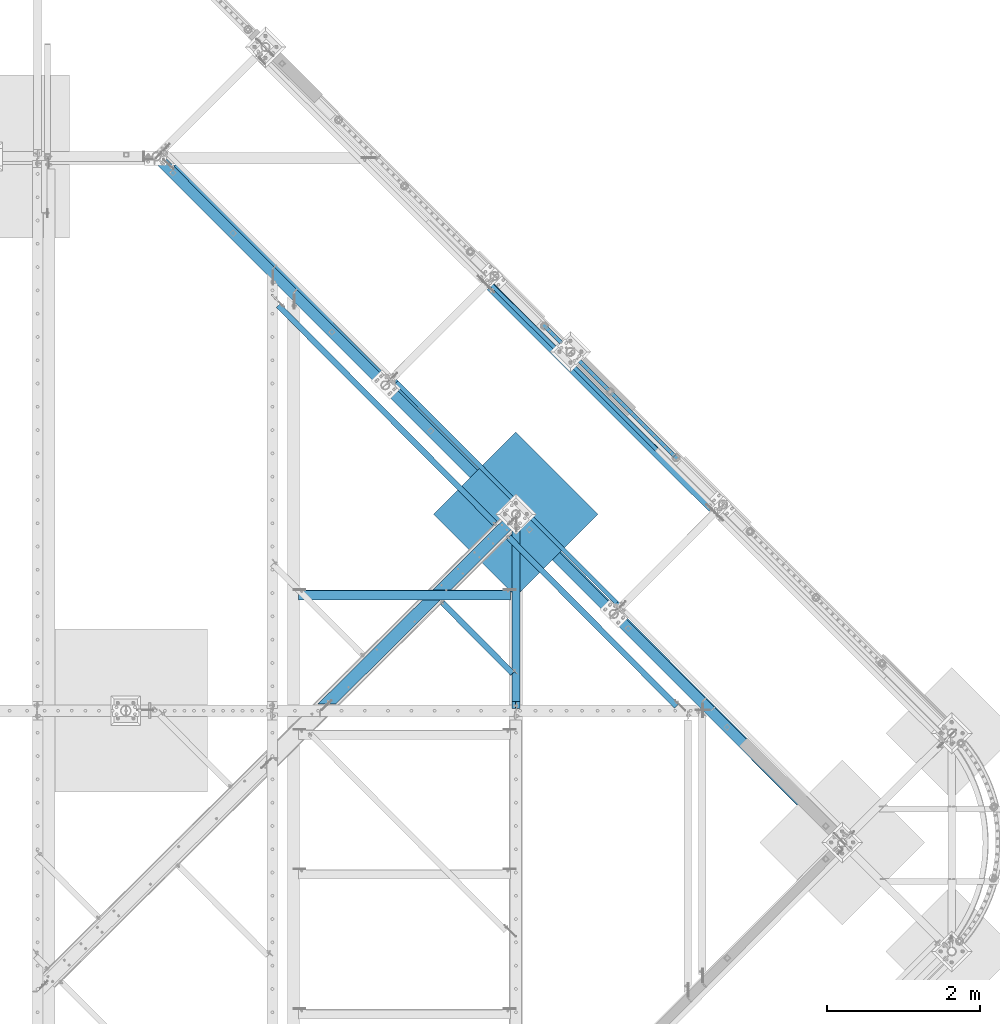
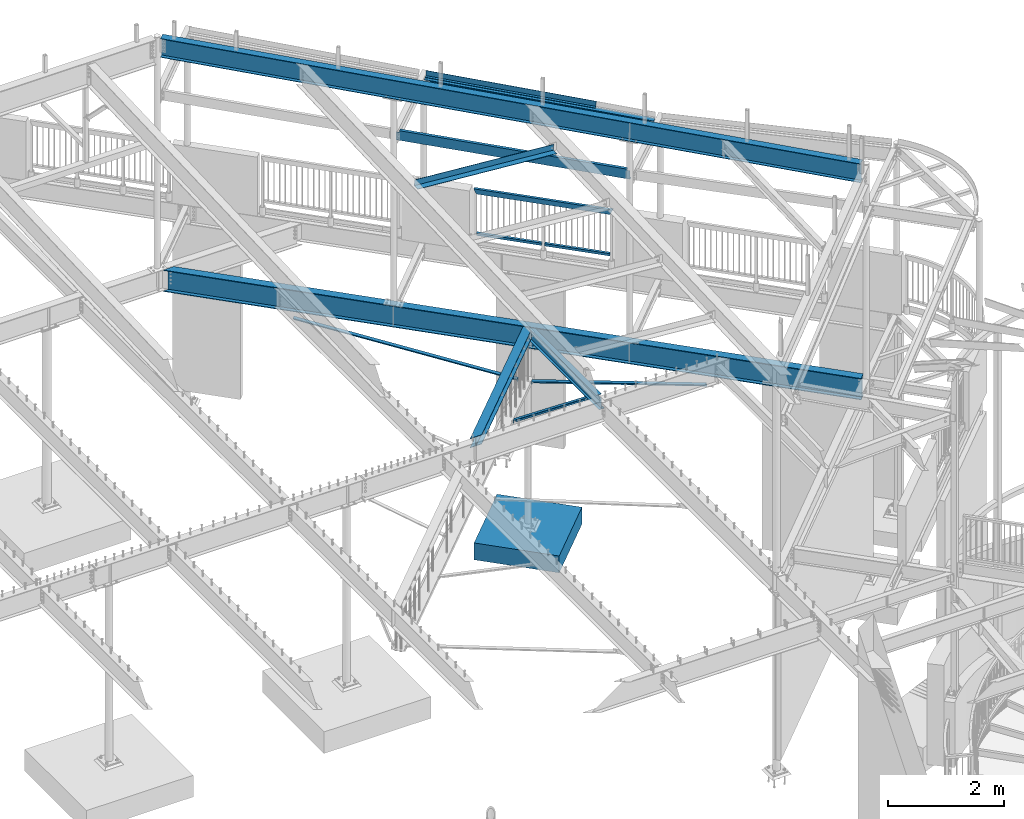
# One storey, part 373 of 975: 15 beams.
"""IFC2X3 building model written with IfcOpenShell, lengths in millimetres."""

from ifc_helpers import new_model, si_unit, frame, origin_with_axes, place, context, subcontext, project, spatial, faceted_brep, material, type_object, element, save


model = new_model("IFC2X3")

# Units and contexts
model_context = context("Model", 3, precision=1e-05, world=origin_with_axes())
body_context = subcontext(model_context, "Body", "Model", "MODEL_VIEW")
ifc_project = project(units=[si_unit("LENGTHUNIT", "METRE", prefix="MILLI"), si_unit("AREAUNIT", "SQUARE_METRE"), si_unit("VOLUMEUNIT", "CUBIC_METRE"), si_unit("MASSUNIT", "GRAM", prefix="KILO"), si_unit("TIMEUNIT", "SECOND"), si_unit("PLANEANGLEUNIT", "RADIAN"), si_unit("SOLIDANGLEUNIT", "STERADIAN"), si_unit("THERMODYNAMICTEMPERATUREUNIT", "DEGREE_CELSIUS"), si_unit("LUMINOUSINTENSITYUNIT", "LUMEN")], contexts=[model_context])

# Site, building, storey
site_placement = place(None, origin_with_axes())
site = spatial("IfcSite", under=ifc_project, at=site_placement, CompositionType="ELEMENT")
building_placement = place(site_placement, origin_with_axes())
building = spatial("IfcBuilding", under=site, at=building_placement, Name="Undefined", CompositionType="ELEMENT")
storey_placement = place(building_placement, origin_with_axes())
storey = spatial("IfcBuildingStorey", under=building, at=storey_placement, Name="Undefined", CompositionType="ELEMENT", Elevation=0.0)

# Beams
ifc_material_1 = material(Name="STEEL/A36")
beam_type_1 = type_object("IfcBeamType", Name="L3X3X3/16", PredefinedType="NOTDEFINED")
beam_1_placement = place(storey_placement, frame((28897.6420101106, 14778.4779433271, 2870.2), z_axis=(-0.709199630836852, -0.705007718837796, 0.0), x_axis=(0.0, 0.0, 1.0)))
element("IfcBeam", 1, at=beam_1_placement, inside=storey, type_object=beam_type_1, material=ifc_material_1, Name="ANGLE", ObjectType="L3X3X3/16", context=body_context, shape_type="Brep", body=[
    faceted_brep([(25.3999993263515, 33.3375000169253, 38.0997831568893), (25.4000002045141, 38.1000000169333, 38.099783156882), (25.4000002078405, 38.100000016997, -38.1002168458144), (25.3999993296779, 33.3375003807087, -38.0996631641319), (25.3999993294701, 33.337500016989, -33.3377168456427), (89.2477246585408, 33.3375000829601, -33.3382619254771), (89.2477246587487, 33.3374998887612, -38.1012691648793), (26.5509402113553, -0.90219007239466, -38.100226671635), (26.5510748253832, -0.90211636328786, -33.3377266726166), (109.802765615811, -4.29845954950542, -33.3399316989671), (47.1055311905088, -38.5383953173441, -33.3393964411225), (736.520643746514, -1300.93623608511, -33.438308348439), (799.217878199897, -1266.69630036868, -33.4388436062909), (46.8646592112509, -38.0999999688338, -33.3379000934765), (46.8644103387105, -38.099999968832, -38.10040009152), (47.1053429026992, -38.5381249909187, -38.1018964297218), (736.520612510684, -1300.93625333881, -38.200808359572), (113.982392956355, -2.01552683855698, -38.102467371431), (803.397662594292, -1264.41365524128, -38.2013793012811), (92.0730134809646, 38.1000000613858, -38.1007860456557), (92.0769954416164, 38.1000000613221, 38.0992139230439), (113.985405561312, -2.01985206136487, 38.097532446187), (803.398162367575, -1264.4133791822, 37.9986208768532), (109.805589932958, -4.30251444588794, 38.0975681300406), (799.21834673735, -1266.69604156329, 37.9986565607105), (89.2514577452253, 33.3375000594315, 38.0992380451789)], [[[0, 1, 2, 3, 4]], [[5, 6, 7, 8]], [[4, 3, 6, 5]], [[9, 10, 11, 12]], [[10, 13, 14, 15, 16, 11]], [[15, 17, 18, 16]], [[19, 20, 21, 17]], [[17, 21, 22, 18]], [[21, 23, 24, 22]], [[12, 11, 16, 18, 22, 24]], [[23, 9, 12, 24]], [[25, 5, 9, 23]], [[13, 10, 9, 5, 8]], [[14, 13, 8, 7]], [[2, 19, 17, 15, 14, 7, 6, 3]], [[20, 19, 2, 1]], [[25, 23, 21, 20, 1, 0]], [[5, 25, 0, 4]]]),
])
beam_2_placement = place(storey_placement, frame((26613.91134576, 18805.1515826589, 3499.2069360264), z_axis=(-0.709199630836852, -0.705007718837796, 0.0), x_axis=(0.698402953621949, -0.702555536619701, -0.136561459926078)))
element("IfcBeam", 2, at=beam_2_placement, inside=storey, type_object=beam_type_1, material=ifc_material_1, Name="ANGLE", ObjectType="L3X3X3/16", context=body_context, shape_type="Brep", body=[
    faceted_brep([(4204.02731316171, -38.1000131169067, -33.3374999955777), (4204.02731316172, -38.1000130379352, -38.0999999956366), (4204.02731334885, 33.3374881753789, -38.0999999960804), (4204.02731333657, 33.3374881686541, -33.3374999966072), (4212.56568141171, -28.6007595276697, -38.0999999961605), (4212.56568170814, -28.6007594877619, -33.3374999955522), (4217.28356452321, -27.9503860965106, 38.1000000045351), (4212.56568170962, -28.6007595019037, 38.1000000045096), (4217.28356477547, -27.9503860464329, -38.0999999955275), (150.946186465858, -38.1000004248108, -33.3374999999724), (150.946186465987, -38.1000004248108, -38.0999999999767), (4141.76209717846, -38.1000116561163, -38.0999999967644), (4141.76209717834, -38.1000116561154, -33.3374999967637), (150.946186665603, 38.0999995751899, -38.0999999998567), (150.946186653002, 33.337499575191, -33.3374999998632), (150.946186651126, 33.3374995752001, 38.1000000001986), (150.9461866636, 38.0999995751999, 38.1000000002059), (4208.1783277454, 38.0999881569805, 38.1000000034655), (4208.17832774723, 38.0999881569714, -38.099999996597), (4204.02731333484, 33.3374881686623, 38.1000000034583)], [[[0, 1, 2, 3]], [[3, 2, 4, 5]], [[6, 7, 5, 4, 8]], [[9, 10, 11, 12]], [[13, 10, 9, 14, 15, 16]], [[13, 16, 17, 18]], [[18, 17, 6, 8]], [[2, 1, 11, 10, 13, 18, 8, 4]], [[12, 11, 1, 0]], [[14, 9, 12, 0, 3]], [[15, 14, 3, 19]], [[19, 3, 5, 7]], [[17, 16, 15, 19, 7, 6]]]),
])
beam_3_placement = place(storey_placement, frame((29762.5164907667, 15637.825378845, 2870.19999999883), z_axis=(-0.709199630836852, -0.705007718837796, 0.0), x_axis=(0.0, 0.0, 1.0)))
element("IfcBeam", 3, at=beam_3_placement, inside=storey, type_object=beam_type_1, material=ifc_material_1, Name="ANGLE", ObjectType="L3X3X3/16", context=body_context, shape_type="Brep", body=[
    faceted_brep([(25.3999988471701, 33.3375000072774, 38.1002199808863), (25.3999981669754, 38.1000000072836, 38.1002199808863), (25.3999981825341, 38.1000000073491, -38.0997800218902), (25.3999988627288, 33.337499142317, -38.1001112534723), (25.3999988617566, 33.3375000073374, -33.3372800217148), (88.0214063803228, 33.3375000188971, -33.3367376821552), (88.0214063812955, 33.3374998225809, -38.0990429855083), (17.4978253848435, 21.9431252632712, -38.0998484595366), (17.4977459579104, 21.9431126255986, -33.3373484600525), (97.801356415584, -27.1994682261393, -33.3356167277307), (27.2784030916505, -38.5937413643314, -33.3362274994943), (520.8336936932, -3093.37190596623, -33.2346009552493), (591.356647031154, -3081.97763291482, -33.2339901834857), (27.1995347129787, -38.0999999922569, -33.3372644366973), (27.1997051803933, -38.0999999922551, -38.0997644353993), (27.2784682359961, -38.5938892782033, -38.098727496741), (520.833733920797, -3093.37189966205, -37.9971009576329), (102.502951781525, -26.4399979308018, -38.0980760068705), (596.058217481281, -3081.21800840721, -37.9964494677515), (92.0763682910315, 38.1000000264012, -38.099202563877), (92.0736408123948, 38.1000000263375, 38.1007974152781), (102.501909471998, -26.4376313087778, 38.1019239491761), (596.057573839732, -3081.21810927416, 38.2035505703825), (97.8003792504023, -27.1972495179907, 38.1018832310583), (591.356043617202, -3081.97772747758, 38.203509852261), (88.0188493679802, 33.3375000251708, 38.1007622983088)], [[[0, 1, 2, 3, 4]], [[5, 6, 7, 8]], [[4, 3, 6, 5]], [[9, 10, 11, 12]], [[10, 13, 14, 15, 16, 11]], [[15, 17, 18, 16]], [[19, 20, 21, 17]], [[17, 21, 22, 18]], [[21, 23, 24, 22]], [[12, 11, 16, 18, 22, 24]], [[23, 25, 5, 9, 12, 24]], [[13, 10, 9, 5, 8]], [[14, 13, 8, 7]], [[2, 19, 17, 15, 14, 7, 6, 3]], [[20, 19, 2, 1]], [[25, 23, 21, 20, 1, 0]], [[5, 25, 0, 4]]]),
])
ifc_material_2 = material()
beam_type_2 = type_object("IfcBeamType", Name="HSS2X2X.188_TUBES", PredefinedType="NOTDEFINED")
beam_4_placement = place(storey_placement, frame((31066.8280807556, 17567.7896415463, 4229.10075294121), z_axis=(-0.707143406238003, -0.707070154237976, 0.0), x_axis=(-0.707070154237841, 0.707143406237869, -6.17000000467233e-07)))
element("IfcBeam", 4, at=beam_4_placement, inside=storey, type_object=beam_type_2, material=ifc_material_2, Name="HANDRAIL", ObjectType="HSS2X2X.188_TUBES", context=body_context, shape_type="Brep", body=[
    faceted_brep([(25.4008090784755, 20.6375000000126, -20.6375000000844), (25.4008182261714, -20.6374999999962, -20.6375000000407), (1193.80731114153, -20.6374999996497, -20.6375000016997), (1193.80733660824, 20.6375000003582, -20.6375000017506), (25.3986803055723, -20.6374999999962, 20.6375000000189), (1193.80517322093, -20.6374999996497, 20.63749999836), (25.3986711578782, 20.6375000000116, 20.6374999999753), (1193.80519868763, 20.6375000003572, 20.6374999983091), (25.4010547061143, 25.4000000000133, -25.400000000096), (25.3984234192258, 25.4000000000124, 25.3999999999724), (1193.80495494295, 25.400000000358, 25.3999999983134), (1193.80758622984, 25.400000000358, -25.4000000017622), (25.3984346779298, -25.3999999999969, 25.4000000000306), (1193.80492359932, -25.3999999996513, 25.3999999983716), (25.4010659648184, -25.3999999999969, -25.4000000000451), (1193.80755488621, -25.3999999996513, -25.400000001704)], [[[0, 1, 2, 3]], [[1, 4, 5, 2]], [[4, 6, 7, 5]], [[6, 0, 3, 7]], [[8, 9, 10, 11]], [[9, 12, 13, 10]], [[12, 14, 15, 13]], [[14, 8, 11, 15]], [[13, 15, 11, 10], [5, 7, 3, 2]], [[14, 12, 9, 8], [6, 4, 1, 0]]]),
])
beam_5_placement = place(storey_placement, frame((31928.891109491, 16705.637303814, 4229.10009527429), z_axis=(-0.707143406238003, -0.707070154237976, 0.0), x_axis=(-0.707070154237873, 0.7071434062379, 5.39000000270782e-07)))
element("IfcBeam", 5, at=beam_5_placement, inside=storey, type_object=beam_type_2, material=ifc_material_2, Name="HANDRAIL", ObjectType="HSS2X2X.188_TUBES", context=body_context, shape_type="Brep", body=[
    faceted_brep([(25.3959352503016, 20.6374999999971, -20.6375000000698), (25.395957497507, -20.637500000008, -20.6375000000553), (1193.80522150229, -20.6375000002545, -20.6375000017215), (1193.80516464068, 20.6374999997506, -20.637500001736), (25.3984002056568, -20.637500000008, 20.6374999999971), (1193.80308358158, -20.6375000002545, 20.6374999983382), (25.3983779584496, 20.637499999998, 20.6374999999898), (1193.80302671998, 20.6374999997506, 20.6374999983236), (25.3956508323763, 25.3999999999978, -25.4000000000815), (25.3986572424046, 25.3999999999978, 25.3999999999942), (1193.80277347587, 25.3999999997513, 25.399999998328), (1193.80540476288, 25.3999999997513, -25.4000000017404), (25.398684623583, -25.4000000000096, 25.4000000000087), (1193.80284345937, -25.4000000002561, 25.3999999983498), (25.3956782135529, -25.4000000000096, -25.4000000000597), (1193.8054747464, -25.400000000257, -25.4000000017259)], [[[0, 1, 2, 3]], [[1, 4, 5, 2]], [[4, 6, 7, 5]], [[6, 0, 3, 7]], [[8, 9, 10, 11]], [[9, 12, 13, 10]], [[12, 14, 15, 13]], [[14, 8, 11, 15]], [[13, 15, 11, 10], [5, 7, 3, 2]], [[14, 12, 9, 8], [6, 4, 1, 0]]]),
])
beam_type_3 = type_object("IfcBeamType", Name="HSS2X4X.188_TUBES", PredefinedType="NOTDEFINED")
beam_6_placement = place(storey_placement, frame((31928.8963945046, 16705.6425679698, 5130.80000000666), z_axis=(0.0, 0.0, 1.0), x_axis=(-0.70707231784675, 0.707141242846735, 0.0)))
element("IfcBeam", 6, at=beam_6_placement, inside=storey, type_object=beam_type_3, material=ifc_material_2, Name="GUARDRAIL", ObjectType="HSS2X4X.188_TUBES", context=body_context, shape_type="Brep", body=[
    faceted_brep([(23.0198915490837, 20.6374999999994, -46.0375000000031), (23.0198915283145, -20.6374999999966, -46.0375000000085), (2415.39077695601, -20.6374999954423, -46.0375000000004), (2415.39077695595, 20.63750000453, -46.0375000000004), (-23.0198845522937, -20.6374999999985, 46.0375000000058), (2461.43052065577, -20.637499995355, 46.0375000000004), (-23.0198845315244, 20.6374999999973, 46.0375000000113), (2461.43052065571, 20.6375000046173, 46.0375000000004), (25.4012592797953, 25.399999999999, -50.8000000000029), (-25.4012522574303, 25.3999999999967, 50.800000000012), (2463.81188670914, 25.4000000046217, 50.8000000000002), (2413.00941090251, 25.4000000045271, -50.8000000000002), (-25.401252282998, -25.3999999999983, 50.8000000000056), (2463.81188670921, -25.3999999953448, 50.8000000000002), (25.401259254224, -25.399999999996, -50.8000000000102), (2413.00941090258, -25.3999999954467, -50.8000000000002)], [[[0, 1, 2, 3]], [[1, 4, 5, 2]], [[4, 6, 7, 5]], [[6, 0, 3, 7]], [[8, 9, 10, 11]], [[9, 12, 13, 10]], [[12, 14, 15, 13]], [[14, 8, 11, 15]], [[13, 15, 11, 10], [5, 7, 3, 2]], [[14, 12, 9, 8], [6, 4, 1, 0]]]),
])
beam_type_4 = type_object("IfcBeamType", Name="C8X11.5", PredefinedType="NOTDEFINED")
beam_7_placement = place(storey_placement, frame((28212.0481476943, 17744.9910474199, 7442.2164682342), z_axis=(-0.0127286164433972, 0.0127331754435545, -0.999837911146882), x_axis=(0.706865566726338, -0.70711874472624, -0.0180042059930297)))
element("IfcBeam", 7, at=beam_7_placement, inside=storey, type_object=beam_type_4, material=ifc_material_1, Name="BEAM", ObjectType="C8X11.5", context=body_context, shape_type="Brep", body=[
    faceted_brep([(4160.56939785738, -28.5750000072912, -96.8355950008245), (4160.56939785738, -28.5750000072803, -101.600000000823), (4160.56939785748, 28.5749999926411, -101.600000000825), (4160.56939785724, 28.5749999926229, -88.8999998159643), (4160.56939785725, 19.0576241515737, -88.8999998159497), (4160.67436089326, 22.2249999926316, -88.3723150008282), (4161.53612777983, 28.5749999926156, -84.0399202979224), (4161.53612777984, 22.2249999926244, -84.0399202979124), (4164.28914168031, 28.5749999926084, -79.9197438297724), (4164.28914168033, 22.2249999926134, -79.9197438297633), (4168.40931814848, 28.5749999925902, -77.1667299292994), (4168.40931814849, 22.2249999925989, -77.1667299292894), (4173.26939766654, 28.5749999925829, -76.2000000067146), (4173.26939766655, 22.2249999925916, -76.2000000067046), (4208.15702952845, 22.2249999925261, -76.2000000066037), (4208.16773109051, 28.574999992521, -76.2000000066018), (18.4365642043003, -28.5750000001535, 101.599999999971), (18.3507709691185, -28.5750000001462, 96.8355949999732), (4211.18729057694, -28.5750000076659, 96.8355949991192), (4211.27308381212, -28.5750000076769, 101.599999999117), (18.5023770780217, 28.5749999997752, 101.599999999969), (4211.36939787061, 28.5749999922518, 101.599999999116), (76.340374749816, 22.2249999999513, -80.7383896419924), (76.3476872913989, 28.5749999999389, -80.7383896387919), (75.9720296713549, 28.5749999999716, -101.599999999994), (75.9062167974971, -28.5749999999534, -101.599999999992), (75.9920100326763, -28.5749999999571, -96.8355949999932), (76.2029097037275, 22.2249999999585, -88.372314999996), (75.4613027550622, 22.2249999999403, -75.8616926944906), (75.4686152966451, 28.5749999999316, -75.8616926912891), (72.7829137675853, 22.2249999999403, -71.6926182636198), (72.7902263091719, 28.5749999999316, -71.6926182604184), (68.7129682310797, 22.224999999944, -68.8658701387285), (68.7202807726608, 28.5749999999389, -68.8658701355262), (63.8710784593222, 22.2249999999549, -67.8117950972937), (63.8783910009015, 28.5749999999425, -67.8117950940923), (15.4601427503612, 22.2250000000386, -66.9400544949603), (15.4674552919441, 28.5750000000298, -66.9400544917626), (18.2568719625915, 22.2249999997985, 88.3723149999732), (4211.12050373465, 22.2249999922824, 88.3723149991192)], [[[0, 1, 2, 3, 4]], [[5, 4, 3, 6, 7]], [[7, 6, 8, 9]], [[9, 8, 10, 11]], [[11, 10, 12, 13]], [[14, 13, 12, 15]], [[16, 17, 18, 19]], [[20, 16, 19, 21]], [[22, 23, 24, 25, 26, 27]], [[28, 29, 23, 22]], [[30, 31, 29, 28]], [[32, 33, 31, 30]], [[34, 35, 33, 32]], [[36, 37, 35, 34]], [[38, 17, 16, 20, 37, 36]], [[17, 38, 39, 18]], [[21, 19, 18, 39, 14, 15]], [[10, 8, 6, 3, 2, 24, 23, 29, 31, 33, 35, 37, 20, 21, 15, 12]], [[25, 24, 2, 1]], [[26, 25, 1, 0]], [[27, 26, 0, 4, 5]], [[39, 38, 36, 34, 32, 30, 28, 22, 27, 5, 7, 9, 11, 13, 14]]]),
])
beam_type_5 = type_object("IfcBeamType", Name="L5X5X5/16", PredefinedType="NOTDEFINED")
beam_8_placement = place(storey_placement, frame((26920.8249998945, 14908.0718563048, 8526.04988149769), z_axis=(0.0796654699609281, 0.0, 0.996821655511107), x_axis=(0.996821655511107, 0.0, -0.0796654699609281)))
element("IfcBeam", 8, at=beam_8_placement, inside=storey, type_object=beam_type_5, material=ifc_material_1, ObjectType="L5X5X5/16", context=body_context, shape_type="Brep", body=[
    faceted_brep([(67.8053474811386, 63.5, -63.5000000000291), (67.805347481346, 63.5, 63.5000000000564), (2852.95282830662, 63.5, 63.5000000004839), (2852.9528283064, 63.5, -63.4999999996035), (67.805347481346, 55.5625, 63.5000000000564), (2852.95282830662, 55.5625, 63.5000000004839), (67.8053474811495, 55.5625, -55.5625000000236), (2852.95282830642, 55.5625, -55.562499999598), (67.8053474811495, -63.5, -55.5625000000236), (2852.95282830642, -63.5, -55.562499999598), (67.8053474811386, -63.5, -63.5000000000291), (2852.9528283064, -63.5, -63.4999999996035)], [[[0, 1, 2, 3]], [[1, 4, 5, 2]], [[4, 6, 7, 5]], [[6, 8, 9, 7]], [[8, 10, 11, 9]], [[10, 0, 3, 11]], [[5, 7, 9, 11, 3, 2]], [[10, 8, 6, 4, 1, 0]]]),
])
beam_type_6 = type_object("IfcBeamType", PredefinedType="NOTDEFINED")
beam_9_placement = place(storey_placement, frame((30576.5324890228, 17869.5424240011, 7405.78202579213), z_axis=(0.707509676766855, -0.705932996704191, -0.0329948699876541), x_axis=(0.706317571755026, 0.707895110754471, 0.0)))
element("IfcBeam", 9, at=beam_9_placement, inside=storey, type_object=beam_type_6, material=ifc_material_1, Name="DECK_EDGE", context=body_context, shape_type="Brep", body=[
    faceted_brep([(-1.44573277793825e-08, -3.17500000027667, -1523.99999999641), (7.79618858359754e-09, -3.17499999972461, 1523.99999999641), (1.44573277793825e-08, 3.17500000027576, 1523.99999999641), (-7.79255060479045e-09, 3.17499999972188, -1523.9999999964), (51.3282235099323, 3.17500000138443, 1523.99999999883), (51.3282235078514, 3.17500000009932, -1523.99999999884), (57.6782232685582, -3.17499999981101, -1523.99999999882), (57.6782232706391, -3.17499999852589, 1523.99999999885), (51.3282275774545, 111.125003231497, 1523.99999999851), (51.3282275765887, 111.125003228997, -1523.99999999916), (57.6782275774676, 111.125002992181, 1523.99999999851), (57.6782275766018, 111.125002989683, -1523.99999999917)], [[[0, 1, 2, 3]], [[3, 2, 4, 5]], [[1, 0, 6, 7]], [[5, 4, 8, 9]], [[4, 2, 1, 7, 10, 8]], [[7, 6, 11, 10]], [[6, 0, 3, 5, 9, 11]], [[10, 11, 9, 8]]]),
])
ifc_material_3 = material(Name="STEEL/A992")
beam_type_7 = type_object("IfcBeamType", Name="W8X24", PredefinedType="NOTDEFINED")
beam_10_placement = place(storey_placement, frame((27269.2700655018, 13392.1499999924, 3836.9875), z_axis=(0.0, 0.0, 1.0), x_axis=(0.709199573009271, 0.70500777700921, 0.0)))
element("IfcBeam", 10, at=beam_10_placement, inside=storey, type_object=beam_type_7, material=ifc_material_3, Name="BEAM", ObjectType="W8X24", context=body_context, shape_type="Brep", body=[
    faceted_brep([(3442.3759339616, -82.5499999972017, 100.0125), (3442.3759339616, -82.5499999972017, 90.4875000000002), (3521.28178049076, -3.17499999701249, 90.4875000000002), (3521.28178049076, -3.17499947762371, 100.0125), (3541.90348349708, -3.17500151060449, 100.0125), (3541.90348349708, -3.17499999699612, 90.4875000000002), (3442.3759339616, -82.5499999972017, -90.4875000000002), (3442.3759339616, -82.5499999972017, -100.0125), (3521.28178049076, -3.17499947762371, -100.0125), (3521.28178049076, -3.17499999701249, -90.4875000000002), (3541.90348349708, -3.17499999699612, -90.4875000000002), (3541.90348349708, -3.17500151060449, -100.0125), (125.462032533324, -3.17499999989559, -90.4875000000002), (205.308975989981, -82.549999999952, -90.4875000000002), (205.308975989981, -82.549999999952, -100.0125), (39.2273336001272, 82.5500000001612, -100.0125), (3541.90348349708, 82.550000003137, -100.0125), (39.2273336001272, 82.5500000001612, 90.4875000000002), (39.2273336001272, 82.5500000001612, 100.0125), (3541.90348349708, 82.550000003137, 100.0125), (3541.90348349708, 82.550000003137, 90.4875000000002), (119.074277056792, 3.17500000010477, 90.4875000000002), (3541.90348349708, 3.17500000301152, 90.4875000000002), (119.074277056792, 3.17500000010477, -90.4875000000002), (3541.90348349708, 3.17500000301152, -90.4875000000002), (39.2273336001272, 82.5500000001612, -90.4875000000002), (3541.90348349708, 82.550000003137, -90.4875000000002), (125.462032533324, -3.17499999989559, 90.4875000000002), (205.308975989981, -82.549999999952, 90.4875000000002), (205.308975989981, -82.549999999952, 100.0125)], [[[0, 1, 2, 3]], [[4, 3, 2, 5]], [[6, 7, 8, 9]], [[10, 9, 8, 11]], [[12, 13, 6, 9]], [[13, 14, 7, 6]], [[7, 14, 15, 16, 11, 8]], [[17, 18, 19, 20]], [[21, 17, 20, 22]], [[23, 21, 22, 24]], [[25, 23, 24, 26]], [[15, 25, 26, 16]], [[14, 13, 12, 27, 28, 29, 18, 17, 21, 23, 25, 15]], [[28, 27, 2, 1]], [[29, 28, 1, 0]], [[19, 18, 29, 0, 3, 4]], [[10, 11, 16, 26, 24, 22, 20, 19, 4, 5]], [[2, 27, 12, 9, 10, 5]]]),
])
beam_type_8 = type_object("IfcBeamType", Name="W10X12", PredefinedType="NOTDEFINED")
beam_11_placement = place(storey_placement, frame((29832.3, 13392.15, 3811.5875), z_axis=(0.0, 0.0, 1.0), x_axis=(0.0, 1.0, 0.0)))
element("IfcBeam", 11, at=beam_11_placement, inside=storey, type_object=beam_type_8, material=ifc_material_3, Name="BEAM", ObjectType="W10X12", context=body_context, shape_type="Brep", body=[
    faceted_brep([(2451.8772505076, 6.18835889114416, 125.4125), (2451.8772505076, 6.18835889114416, 120.65), (2451.8772505076, 50.7999999999993, 120.65), (2451.8772505076, 50.7999999999993, 125.4125), (2451.8772505076, 6.18835889114416, -120.65), (2451.8772505076, 6.18835889114416, -125.4125), (2451.8772505076, 50.7999999999993, -125.4125), (2451.8772505076, 50.7999999999993, -120.65), (118.268750000007, 50.8000000000002, 120.65), (118.268750000007, 50.8000000000002, 125.4125), (2448.04750552031, 2.38124999999854, 120.65), (118.268750000007, 2.38125000000036, 120.65), (29.3687500000015, 2.38125000000036, -120.65), (29.3687500000015, 50.8000000000002, -120.65), (29.3687500000015, 50.8000000000002, -125.4125), (29.3687500000015, -50.8000000000002, -125.4125), (29.3687500000015, -50.8000000000002, -120.65), (29.3687500000015, -2.38125000000036, -120.65), (29.3687500000015, -2.38125000000036, 100.0125), (29.3687500000015, 2.38125000000036, 100.0125), (105.568750190741, -2.38125000000036, 100.0125), (105.568750190741, 2.38125000000036, 100.0125), (110.428829708788, -2.38125000000036, 100.979229922588), (110.428829708788, 2.38125000000036, 100.979229922588), (114.549006176941, -2.38125000000036, 103.732243823066), (114.549006176941, 2.38125000000036, 103.732243823066), (117.302020077419, -2.38125000000036, 107.85242029122), (117.302020077419, 2.38125000000036, 107.85242029122), (118.268750000007, -2.38125000000036, 112.712499809265), (118.268750000007, 2.38125000000036, 112.712499809265), (2448.04750552031, 2.38124999999854, -120.65), (2394.55005340411, -50.7999999999993, -125.4125), (2394.55005340411, -50.7999999999993, -120.65), (2443.25668891289, -2.38124999999854, -120.65), (2443.25668891289, -2.38124999999854, 120.65), (118.268750000007, -2.38125000000036, 120.65), (2394.55005340411, -50.7999999999993, 120.65), (118.268750000007, -50.8000000000002, 120.65), (118.268750000007, -50.8000000000002, 125.41249981212), (2394.55005340411, -50.7999999999993, 125.4125)], [[[0, 1, 2, 3]], [[4, 5, 6, 7]], [[8, 9, 3, 2]], [[10, 11, 8, 2, 1]], [[12, 13, 14, 15, 16, 17, 18, 19]], [[20, 21, 19, 18]], [[22, 23, 21, 20]], [[24, 25, 23, 22]], [[26, 27, 25, 24]], [[28, 29, 27, 26]], [[10, 30, 12, 19, 21, 23, 25, 27, 29, 11]], [[13, 12, 30, 4, 7]], [[14, 13, 7, 6]], [[31, 15, 14, 6, 5]], [[16, 15, 31, 32]], [[17, 16, 32, 33]], [[26, 24, 22, 20, 18, 17, 33, 34, 35, 28]], [[34, 36, 37, 35]], [[38, 9, 8, 11, 29, 28, 35, 37]], [[36, 39, 38, 37]], [[9, 38, 39, 0, 3]], [[39, 36, 34, 33, 32, 31, 5, 4, 30, 10, 1, 0]]]),
])
beam_type_9 = type_object("IfcBeamType", Name="W12X14", PredefinedType="NOTDEFINED")
beam_12_placement = place(storey_placement, frame((29442.6813909214, 18982.9263446819, 7304.16961402586), z_axis=(-0.0233565065242401, 0.023305198525286, -0.99945552243443), x_axis=(0.707498431185309, -0.705944269184903, -0.0329948280086422)))
element("IfcBeam", 12, at=beam_12_placement, inside=storey, type_object=beam_type_9, material=ifc_material_3, Name="BEAM", ObjectType="W12X14", context=body_context, shape_type="Brep", body=[
    faceted_brep([(77.8073075249704, -2.38124999994034, 85.846152505309), (77.812660505243, 2.38125000006403, 85.8459757911178), (68.7015710828737, 2.3812500000422, 86.1471474669197), (68.7021766122289, -2.38124999996217, 86.1471272195549), (80.2519913396163, -2.38124999994034, 86.2489711672315), (80.2573443198926, 2.3812500000713, 86.2487944530412), (82.3564325385687, -2.38124999992579, 87.5566664556909), (82.3617855188422, 2.3812500000713, 87.5564897415006), (83.8002490551407, -2.38124999992579, 89.5701536353608), (83.8056020354124, 2.3812500000713, 89.5699769211706), (84.3636329328501, -2.38124999993306, 91.9828975632408), (84.3689859131227, 2.38125000006403, 91.9827208490506), (86.2537981385403, -50.8000000000029, 150.812500000066), (86.3681196670532, 50.8000000000393, 150.812500000064), (86.1582167416573, 50.8000000000466, 144.462500000061), (86.1037353882266, 2.38125000002037, 144.462500000062), (86.0983765665787, -2.38124999997672, 144.462500000062), (86.0438952131444, -50.7999999999956, 144.462500000064), (61.0891064394709, -2.38124999975844, -144.462500000058), (61.0952694502121, -50.7999999997701, -144.462500000057), (4172.62938288698, -50.7999999921158, -144.462499999935), (4172.64907100541, -2.38124999210413, -144.462499999938), (60.8856381517289, -50.7999999997701, -150.81250000006), (4172.41975159072, -50.7999999921085, -150.812499999938), (60.8727059324647, 50.8000000002648, -150.812500000063), (4172.46106436381, 50.8000000079192, -150.812499999943), (61.0823372309505, 50.8000000002648, -144.46250000006), (4172.67069566007, 50.8000000079192, -144.462499999939), (61.0885002416935, 2.38125000024593, -144.462500000059), (4172.65100754164, 2.38125000790023, -144.462499999937), (4180.2422556666, 2.38125000770378, 85.4861119361367), (4180.24032122578, -2.38124999230058, 85.4861754089898), (4172.007344799, 2.38125000768196, 85.7589041006058), (4172.00199182211, -2.38124999231513, 85.7590808169298), (4169.59463902909, 2.38125000768196, 86.3224582258044), (4169.5892860522, -2.38124999232241, 86.3226349421284), (4167.58125247483, 2.38125000767468, 87.7664162812725), (4167.57589949793, -2.38124999232969, 87.7665929975965), (4166.27370498769, 2.3812500076674, 89.8709487425776), (4166.2683520108, -2.38124999232969, 89.8711254589016), (4165.87105881966, 2.3812500076674, 92.3156596201206), (4165.86570584277, -2.38124999232969, 92.3158363364446), (4167.74900269347, -50.7999999924068, 150.812500000187), (4167.53865065937, -50.7999999923923, 144.462500000184), (4167.59313210629, -2.38124999237334, 144.462500000183), (4167.59849093714, 2.38125000762375, 144.462500000183), (4167.65297238406, 50.8000000076427, 144.462500000182), (4167.86332441815, 50.8000000076354, 150.812500000185)], [[[0, 1, 2, 3]], [[4, 5, 1, 0]], [[6, 7, 5, 4]], [[8, 9, 7, 6]], [[10, 11, 9, 8]], [[12, 13, 14, 15, 11, 10, 16, 17]], [[18, 19, 20, 21]], [[19, 22, 23, 20]], [[22, 24, 25, 23]], [[24, 26, 27, 25]], [[26, 28, 29, 27]], [[21, 20, 23, 25, 27, 29, 30, 31]], [[31, 30, 32, 33]], [[33, 32, 34, 35]], [[35, 34, 36, 37]], [[37, 36, 38, 39]], [[39, 38, 40, 41]], [[42, 43, 44, 41, 40, 45, 46, 47]], [[43, 42, 12, 17]], [[44, 43, 17, 16]], [[8, 6, 4, 0, 3, 18, 21, 31, 33, 35, 37, 39, 41, 44, 16, 10]], [[28, 26, 24, 22, 19, 18, 3, 2]], [[45, 40, 38, 36, 34, 32, 30, 29, 28, 2, 1, 5, 7, 9, 11, 15]], [[46, 45, 15, 14]], [[47, 46, 14, 13]], [[42, 47, 13, 12]]]),
])
beam_type_10 = type_object("IfcBeamType", Name="W18X40", PredefinedType="NOTDEFINED")
beam_13_placement = place(storey_placement, frame((25201.9955038776, 20621.7350997309, 3709.9875), z_axis=(0.0, 0.0, 1.0), x_axis=(0.705007777009209, -0.709199573009272, 0.0)))
element("IfcBeam", 13, at=beam_13_placement, inside=storey, type_object=beam_type_10, material=ifc_material_3, Name="BEAM", ObjectType="W18X40", context=body_context, shape_type="Brep", body=[
    faceted_brep([(201.102197533599, 76.2000000004555, -227.0125), (201.102197533599, 76.2000000004555, -214.3125), (12557.113610987, 76.2000000268854, -214.3125), (12557.113610987, 76.2000000268854, -227.0125), (129.297877661918, 3.96875000028012, -214.3125), (12557.113610987, 3.96875002686647, -214.3125), (129.297877661918, 3.96875000028012, 214.3125), (12557.113610987, 3.96875002686647, 214.3125), (201.102197533599, 76.2000000004555, 214.3125), (12557.113610987, 76.2000000268854, 214.3125), (201.102197533599, 76.2000000004555, 227.0125), (12557.113610987, 76.2000000268854, 227.0125), (49.6029731889521, -76.1999999999098, 227.0125), (12557.1136109869, -76.1999999731524, 227.0125), (49.6029731889521, -76.1999999999098, 214.3125), (12557.1136109869, -76.1999999731524, 214.3125), (121.407293060633, -3.96874999973443, 214.3125), (12557.1136109869, -3.96874997313353, 214.3125), (121.407293060633, -3.96874999973443, -214.3125), (12557.1136109869, -3.96874997313353, -214.3125), (49.6029731889521, -76.1999999999098, -214.3125), (12557.1136109869, -76.1999999731524, -214.3125), (49.6029731889521, -76.1999999999098, -227.0125), (12557.1136109869, -76.1999999731524, -227.0125)], [[[0, 1, 2, 3]], [[1, 4, 5, 2]], [[4, 6, 7, 5]], [[6, 8, 9, 7]], [[8, 10, 11, 9]], [[10, 12, 13, 11]], [[12, 14, 15, 13]], [[14, 16, 17, 15]], [[16, 18, 19, 17]], [[18, 20, 21, 19]], [[20, 22, 23, 21]], [[22, 0, 3, 23]], [[5, 7, 9, 11, 13, 15, 17, 19, 21, 23, 3, 2]], [[22, 20, 18, 16, 14, 12, 10, 8, 6, 4, 1, 0]]]),
])
beam_type_11 = type_object("IfcBeamType", Name="W16X26", PredefinedType="NOTDEFINED")
beam_14_placement = place(storey_placement, frame((25122.7508468638, 20651.2677371263, 8639.26498077964), z_axis=(-0.0212034286822236, 0.0212110253315295, -0.999550152326787), x_axis=(0.706662090021219, -0.706915269021226, -0.0299915480009005)))
element("IfcBeam", 14, at=beam_14_placement, inside=storey, type_object=beam_type_11, material=ifc_material_3, Name="BEAM", ObjectType="W16X26", context=body_context, shape_type="Brep", body=[
    faceted_brep([(81.8832247707883, -69.8500000004351, -200.024999999914), (81.8832247632931, 69.8499999996166, -200.025000000014), (12621.1819293605, 69.849999980117, -200.024999999912), (12621.181929368, -69.8500000199238, -200.02499999981), (82.1690228243506, -69.8500000004206, -190.499999999916), (82.1690228207713, -3.17500000039581, -190.499999999964), (93.6009449631047, -3.17499999988286, 190.499999999973), (93.600944966684, -69.849999999904, 190.50000000002), (93.886743020244, -69.849999999893, 200.02500000002), (93.8867430127434, 69.8500000001586, 200.02499999992), (93.6009449591888, 69.8500000001404, 190.499999999918), (93.6009449627663, 3.17500000011933, 190.499999999969), (82.1690228204325, 3.17499999960273, -190.499999999967), (82.1690228168513, 69.8499999996275, -190.500000000016), (12621.4677274283, -69.8500000199165, -190.499999999813), (12621.4677274247, -3.17500001989174, -190.499999999862), (12632.8996498367, -3.17500001936787, 190.500000000076), (12632.8996498402, -69.8500000193926, 190.500000000124), (12633.1854479005, -69.850000019389, 200.025000000122), (12633.185447893, 69.849999980659, 200.02500000002), (12632.8996498327, 69.8499999806481, 190.500000000022), (12632.8996498363, 3.17499998063067, 190.500000000069), (12621.4677274244, 3.17499998011044, -190.499999999865), (12621.4677274208, 69.8499999801279, -190.499999999915)], [[[0, 1, 2, 3]], [[0, 4, 5, 6, 7, 8, 9, 10, 11, 12, 13, 1]], [[5, 4, 14, 15]], [[6, 5, 15, 16]], [[7, 6, 16, 17]], [[8, 7, 17, 18]], [[9, 8, 18, 19]], [[10, 9, 19, 20]], [[11, 10, 20, 21]], [[12, 11, 21, 22]], [[13, 12, 22, 23]], [[1, 13, 23, 2]], [[22, 21, 20, 19, 18, 17, 16, 15, 14, 3, 2, 23]], [[4, 0, 3, 14]]]),
])
ifc_material_4 = material(Name="CONCRETE/5000")
beam_type_12 = type_object("IfcBeamType", PredefinedType="NOTDEFINED")
beam_15_placement = place(storey_placement, frame((29293.4846327422, 15425.0846327366, -482.6), z_axis=(0.0, 0.0, -1.0), x_axis=(0.707106781186548, 0.707106781186548, 0.0)))
element("IfcBeam", 15, at=beam_15_placement, inside=storey, type_object=beam_type_12, material=ifc_material_4, Name="FOOTING", context=body_context, shape_type="Brep", body=[
    faceted_brep([(4.8748916015029e-10, 762.000000001049, -177.8), (4.8748916015029e-10, 762.000000001049, 177.8), (1524.00000000259, 762.000000000074, 177.8), (1524.00000000259, 762.000000000074, -177.8), (-4.80213202536106e-10, -762.000000001047, 177.8), (1524.00000000162, -762.00000000202, 177.8), (-4.80213202536106e-10, -762.000000001047, -177.8), (1524.00000000162, -762.00000000202, -177.8)], [[[0, 1, 2, 3]], [[1, 4, 5, 2]], [[4, 6, 7, 5]], [[6, 0, 3, 7]], [[5, 7, 3, 2]], [[6, 4, 1, 0]]]),
])

save(model, "model.ifc")
